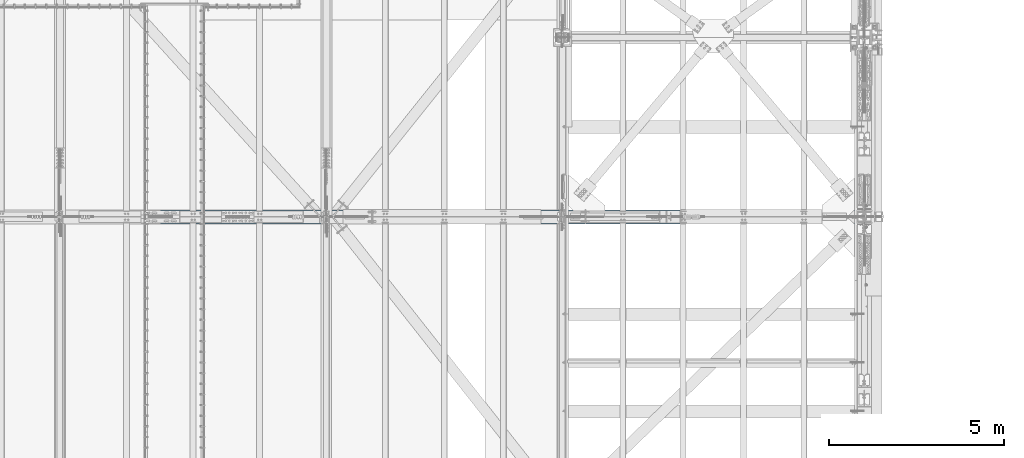
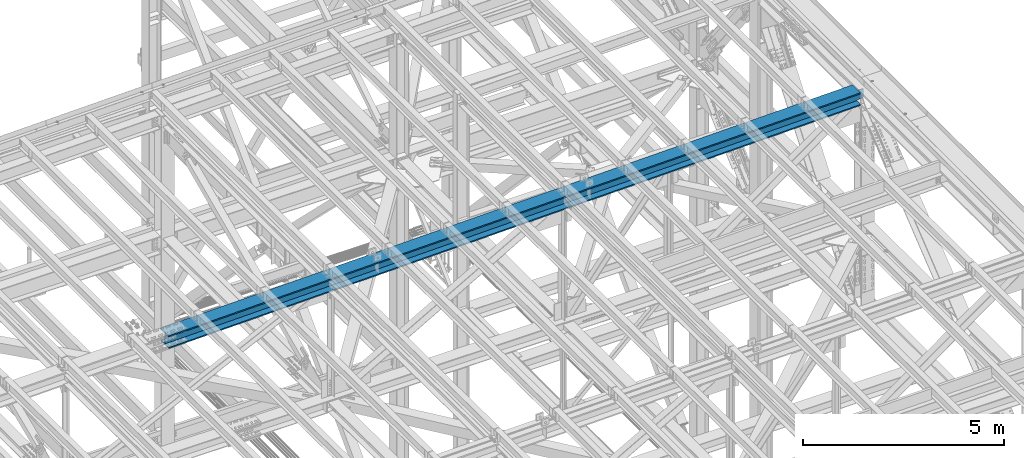
# One storey, part 1924 of 3843: 1 beam, 1 element without a shape of its own.
"""IFC2X3 building model written with IfcOpenShell, lengths in millimetres."""

from ifc_helpers import new_model, si_unit, frame, origin_with_axes, place, context, subcontext, project, spatial, faceted_brep, material, type_object, element, aggregate, save


model = new_model("IFC2X3")

# Units and contexts
model_context = context("Model", 3, precision=1e-05, world=origin_with_axes())
body_context = subcontext(model_context, "Body", "Model", "MODEL_VIEW")
ifc_project = project(units=[si_unit("LENGTHUNIT", "METRE", prefix="MILLI"), si_unit("AREAUNIT", "SQUARE_METRE"), si_unit("VOLUMEUNIT", "CUBIC_METRE"), si_unit("MASSUNIT", "GRAM", prefix="KILO"), si_unit("TIMEUNIT", "SECOND"), si_unit("PLANEANGLEUNIT", "RADIAN"), si_unit("SOLIDANGLEUNIT", "STERADIAN"), si_unit("THERMODYNAMICTEMPERATUREUNIT", "DEGREE_CELSIUS"), si_unit("LUMINOUSINTENSITYUNIT", "LUMEN")], contexts=[model_context])

# Site, building, storey
site_placement = place(None, origin_with_axes())
site = spatial("IfcSite", under=ifc_project, at=site_placement, CompositionType="ELEMENT")
building_placement = place(site_placement, origin_with_axes())
building = spatial("IfcBuilding", under=site, at=building_placement, Name="Undefined", CompositionType="ELEMENT")
storey_placement = place(building_placement, origin_with_axes())
storey = spatial("IfcBuildingStorey", under=building, at=storey_placement, Name="Undefined", CompositionType="ELEMENT", Elevation=0.0)

# Assembly, beam
assembly_placement = place(storey_placement, origin_with_axes())
assembly = element("IfcElementAssembly", 1, at=assembly_placement, inside=storey, Name="BEAM", AssemblyPlace="NOTDEFINED", PredefinedType="RIGID_FRAME")
ifc_material = material(Name="STEEL/A992")
beam_type = type_object("IfcBeamType", Name="W14X193", PredefinedType="NOTDEFINED")
beam_placement = place(assembly_placement, frame((65510.858701952, 83985.1, 45847.6093685375), z_axis=(-0.0216342480057937, 0.0, 0.999765952267441), x_axis=(0.999765952267441, 0.0, 0.0216342480057898)))
beam = element("IfcBeam", 2, at=beam_placement, type_object=beam_type, material=ifc_material, Name="BEAM", ObjectType="W14X193", context=body_context, shape_type="Brep", body=[
    faceted_brep([(19922.2775877108, -11.1125000000029, -160.337500066009), (19922.2775877108, -200.025000000001, -160.337500066009), (19922.2775877106, -200.025000000001, -196.850000066108), (19922.2775877106, 200.025000000001, -196.850000066108), (19922.2775877108, 200.025000000001, -160.337500066009), (19922.2775877108, 11.1125000000029, -160.337500066009), (19922.2775877108, 11.1125000000029, -152.400001131209), (19922.2775877108, -11.1125000000029, -152.400001131209), (19923.2443176334, 11.1125000000029, -147.539921613119), (19923.2443176334, -11.1125000000029, -147.539921613119), (19925.9973315339, 11.1125000000029, -143.419745144944), (19925.9973315339, -11.1125000000029, -143.419745144944), (19930.1175080021, 11.1125000000029, -140.666731244455), (19930.1175080021, -11.1125000000029, -140.666731244455), (19934.9775875202, 11.1125000000029, -139.700001321871), (19934.9775875202, -11.1125000000029, -139.700001321871), (20111.8448756608, -11.1125000000029, -139.700001322446), (20111.8448756608, 11.1125000000029, -139.700001322446), (6.34999999676074, 11.1125000000029, 160.337500000445), (6.34999999676074, 200.025000000001, 160.337500000445), (19928.627587712, 200.025000000001, 160.337499934882), (19928.627587712, 11.1125000000029, 160.337499934882), (6.34999999676074, -200.025000000001, -196.850000000573), (6.3499999967753, -200.025000000001, -160.337500000467), (6.3499999967753, -11.1125000000029, -160.337500000467), (6.34999999676074, -11.1125000000029, 160.337500000445), (6.34999999676074, -200.025000000001, 160.337500000445), (6.3499999967753, -200.025000000001, 196.850000000544), (6.3499999967753, 200.025000000001, 196.850000000544), (6.3499999967753, 11.1125000000029, -160.337500000467), (6.3499999967753, 200.025000000001, -160.337500000467), (6.34999999676074, 200.025000000001, -196.850000000573), (19928.627587712, -11.1125000000029, 160.337499934882), (19928.627587712, -200.025000000001, 160.337499934882), (19928.6275877121, -200.025000000001, 196.849999934988), (19928.6275877121, 200.025000000001, 196.849999934988), (19928.6275877119, -11.1125000000029, 152.399998490277), (19928.6275877119, 11.1125000000029, 152.399998490277), (19929.5943176345, -11.1125000000029, 147.539918972179), (19929.5943176345, 11.1125000000029, 147.539918972179), (19932.347331535, -11.1125000000029, 143.419742503975), (19932.347331535, 11.1125000000029, 143.419742503975), (19936.4675080032, -11.1125000000029, 140.666728603472), (19936.4675080032, 11.1125000000029, 140.666728603472), (19941.3275875213, -11.1125000000029, 139.699998680859), (19941.3275875213, 11.1125000000029, 139.699998680859), (20117.8908998914, -11.1125000000029, 139.699998680269), (20117.8908998914, 11.1125000000029, 139.699998680269)], [[[0, 1, 2, 3, 4, 5, 6, 7]], [[7, 6, 8, 9]], [[9, 8, 10, 11]], [[11, 10, 12, 13]], [[13, 12, 14, 15]], [[16, 15, 14, 17]], [[18, 19, 20, 21]], [[22, 23, 24, 25, 26, 27, 28, 19, 18, 29, 30, 31]], [[26, 25, 32, 33]], [[27, 26, 33, 34]], [[28, 27, 34, 35]], [[19, 28, 35, 20]], [[34, 33, 32, 36, 37, 21, 20, 35]], [[38, 39, 37, 36]], [[40, 41, 39, 38]], [[42, 43, 41, 40]], [[44, 45, 43, 42]], [[46, 47, 45, 44]], [[47, 46, 16, 17]], [[12, 10, 8, 6, 5, 29, 18, 21, 37, 39, 41, 43, 45, 47, 17, 14]], [[30, 29, 5, 4]], [[31, 30, 4, 3]], [[22, 31, 3, 2]], [[23, 22, 2, 1]], [[24, 23, 1, 0]], [[46, 44, 42, 40, 38, 36, 32, 25, 24, 0, 7, 9, 11, 13, 15, 16]]]),
])
aggregate(assembly, [beam])

save(model, "model.ifc")
